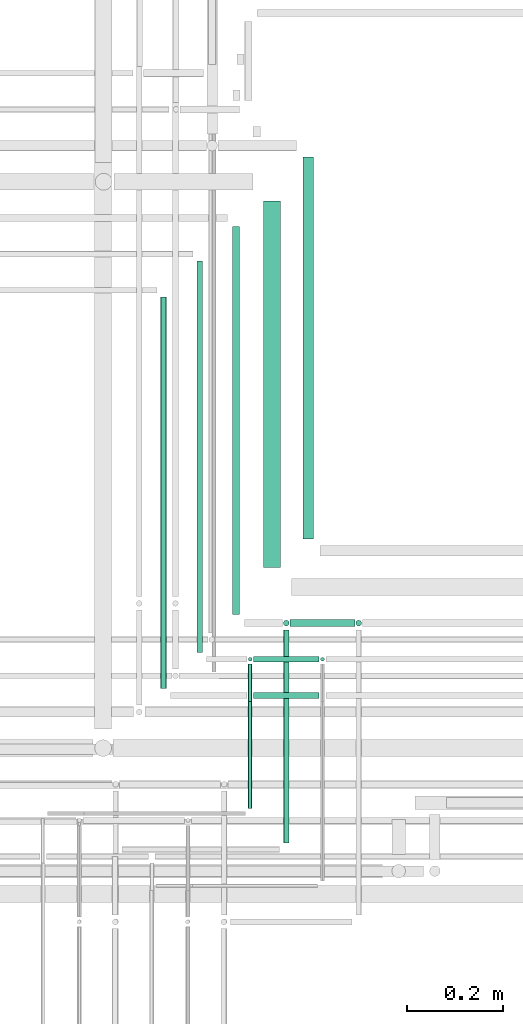
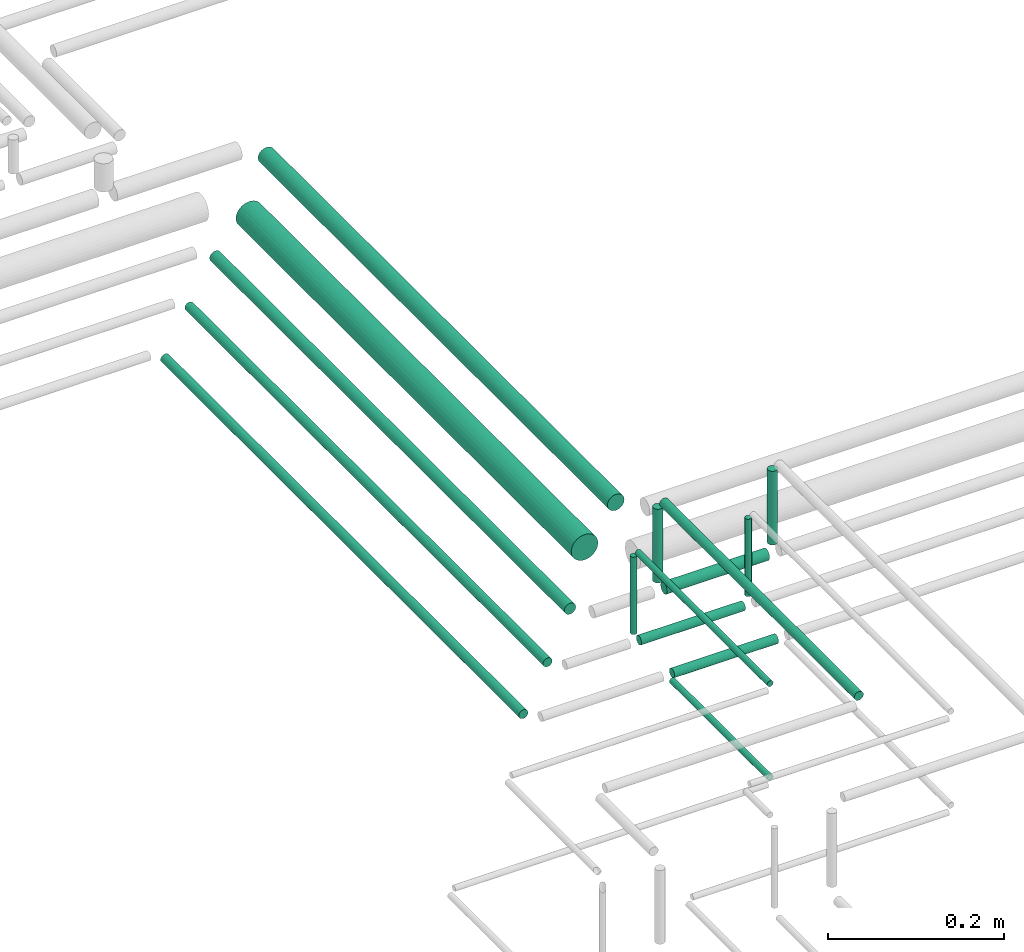
# One storey, part 220 of 331: 15 flow segments.
"""IFC2X3 building model written with IfcOpenShell, lengths in millimetres."""

from ifc_helpers import new_model, entity, si_unit, converted_unit, derived_unit, direction, frame, frame_2d, origin, origin_2d_with_axis, place, context, subcontext, project, spatial, circle, extrude, type_object, element, save


model = new_model("IFC2X3")

# Units and contexts
model_context = context("Model", 3, precision=0.01, world=origin(), true_north=direction((6.12303176911189e-17, 1.0)))
body_context = subcontext(model_context, "Body", "Model", "MODEL_VIEW")
ifc_project = project(units=[si_unit("LENGTHUNIT", "METRE", prefix="MILLI"), si_unit("AREAUNIT", "SQUARE_METRE"), si_unit("VOLUMEUNIT", "CUBIC_METRE"), converted_unit("PLANEANGLEUNIT", "DEGREE", entity("IfcRatioMeasure", 0.0174532925199433), si_unit("PLANEANGLEUNIT", "RADIAN"), dimensions=[0, 0, 0, 0, 0, 0, 0]), si_unit("MASSUNIT", "GRAM", prefix="KILO"), derived_unit("MASSDENSITYUNIT", [(si_unit("MASSUNIT", "GRAM", prefix="KILO"), 1), (si_unit("LENGTHUNIT", "METRE"), -3)]), derived_unit("MOMENTOFINERTIAUNIT", [(si_unit("LENGTHUNIT", "METRE"), 4)]), si_unit("TIMEUNIT", "SECOND"), si_unit("FREQUENCYUNIT", "HERTZ"), si_unit("THERMODYNAMICTEMPERATUREUNIT", "DEGREE_CELSIUS"), derived_unit("THERMALTRANSMITTANCEUNIT", [(si_unit("MASSUNIT", "GRAM", prefix="KILO"), 1), (si_unit("THERMODYNAMICTEMPERATUREUNIT", "KELVIN"), -1), (si_unit("TIMEUNIT", "SECOND"), -3)]), derived_unit("VOLUMETRICFLOWRATEUNIT", [(si_unit("LENGTHUNIT", "METRE"), 3), (si_unit("TIMEUNIT", "SECOND"), -1)]), derived_unit("MASSFLOWRATEUNIT", [(si_unit("MASSUNIT", "GRAM", prefix="KILO"), 1), (si_unit("TIMEUNIT", "SECOND"), -1)]), derived_unit("ROTATIONALFREQUENCYUNIT", [(si_unit("TIMEUNIT", "SECOND"), -1)]), si_unit("ELECTRICCURRENTUNIT", "AMPERE"), si_unit("ELECTRICVOLTAGEUNIT", "VOLT"), si_unit("POWERUNIT", "WATT"), si_unit("FORCEUNIT", "NEWTON", prefix="KILO"), si_unit("ILLUMINANCEUNIT", "LUX"), si_unit("LUMINOUSFLUXUNIT", "LUMEN"), si_unit("LUMINOUSINTENSITYUNIT", "CANDELA"), derived_unit("USERDEFINED", [(si_unit("MASSUNIT", "GRAM", prefix="KILO"), -1), (si_unit("LENGTHUNIT", "METRE"), -2), (si_unit("TIMEUNIT", "SECOND"), 3), (si_unit("LUMINOUSFLUXUNIT", "LUMEN"), 1)]), derived_unit("LINEARVELOCITYUNIT", [(si_unit("LENGTHUNIT", "METRE"), 1), (si_unit("TIMEUNIT", "SECOND"), -1)]), si_unit("PRESSUREUNIT", "PASCAL"), derived_unit("USERDEFINED", [(si_unit("LENGTHUNIT", "METRE"), -2), (si_unit("MASSUNIT", "GRAM", prefix="KILO"), 1), (si_unit("TIMEUNIT", "SECOND"), -2)]), derived_unit("LINEARFORCEUNIT", [(si_unit("MASSUNIT", "GRAM", prefix="KILO"), 1), (si_unit("LENGTHUNIT", "METRE"), 1), (si_unit("TIMEUNIT", "SECOND"), -2), (si_unit("LENGTHUNIT", "METRE"), -1)]), derived_unit("PLANARFORCEUNIT", [(si_unit("MASSUNIT", "GRAM", prefix="KILO"), 1), (si_unit("LENGTHUNIT", "METRE"), 1), (si_unit("TIMEUNIT", "SECOND"), -2), (si_unit("LENGTHUNIT", "METRE"), -2)])], contexts=[model_context])

# Site, building, storey
site_placement = place(None, frame((0.0, -0.00077364408347762, 0.0)))
site = spatial("IfcSite", under=ifc_project, at=site_placement, CompositionType="ELEMENT")
building_placement = place(site_placement, origin())
building = spatial("IfcBuilding", under=site, at=building_placement, CompositionType="ELEMENT")
storey_placement = place(building_placement, origin())
storey = spatial("IfcBuildingStorey", under=building, at=storey_placement, CompositionType="ELEMENT", Elevation=0.0)

# Flow segments
pipe_segment_type = type_object("IfcPipeSegmentType", PredefinedType="NOTDEFINED")
flow_segment_1_placement = place(building_placement, frame((62112.9290801959, 8573.81073448242, 18442.4047277641)))
element("IfcFlowSegment", 1, at=flow_segment_1_placement, inside=storey, type_object=pipe_segment_type, context=body_context, shape_type="SweptSolid", body=[
    extrude(circle(Radius=6.0, at=frame_2d((0.0, -2.16573425859679e-12), x_axis=(1.0, 0.0))), frame((7.59527223591454, 0.0, 7.59527223591454), z_axis=(0.0, 1.0, 0.0), x_axis=(1.0, 0.0, 0.0)), (0.0, 0.0, 1.0), 812.189265517507),
])
flow_segment_2_placement = place(building_placement, frame((62187.9290801959, 8648.81073448242, 18442.4047277641)))
element("IfcFlowSegment", 2, at=flow_segment_2_placement, inside=storey, type_object=pipe_segment_type, context=body_context, shape_type="SweptSolid", body=[
    extrude(circle(Radius=6.0, at=frame_2d((0.0, 2.16573425859679e-12), x_axis=(1.0, 0.0))), frame((7.59527223591454, 0.0, 7.59527223591887), z_axis=(0.0, 1.0, 0.0), x_axis=(1.0, 0.0, 0.0)), (0.0, 0.0, 1.0), 812.189265517507),
])
flow_segment_3_placement = place(building_placement, frame((62261.4290801959, 8727.81073448242, 18440.9047277641)))
element("IfcFlowSegment", 3, at=flow_segment_3_placement, inside=storey, type_object=pipe_segment_type, context=body_context, shape_type="SweptSolid", body=[
    extrude(circle(Radius=7.5, at=origin_2d_with_axis()), frame((9.09527223591419, 0.0, 9.09527223591636), z_axis=(0.0, 1.0, 0.0), x_axis=(1.0, 0.0, 0.0)), (0.0, 0.0, 1.0), 804.189265517482),
])
flow_segment_4_placement = place(building_placement, frame((62326.4290801959, 8824.81073448212, 18430.9047277641)))
element("IfcFlowSegment", 4, at=flow_segment_4_placement, inside=storey, type_object=pipe_segment_type, context=body_context, shape_type="SweptSolid", body=[
    extrude(circle(Radius=17.5, at=origin_2d_with_axis()), frame((19.0952722359119, 0.0, 19.0952722359163), z_axis=(0.0, 1.0, 0.0), x_axis=(1.0, 0.0, 0.0)), (0.0, 0.0, 1.0), 760.189265517799),
])
flow_segment_5_placement = place(building_placement, frame((62407.9290801959, 8883.81073448209, 18437.4047277641)))
element("IfcFlowSegment", 5, at=flow_segment_5_placement, inside=storey, type_object=pipe_segment_type, context=body_context, shape_type="SweptSolid", body=[
    extrude(circle(Radius=11.0, at=origin_2d_with_axis()), frame((12.5952722359134, 0.0, 12.5952722359156), z_axis=(0.0, 1.0, 0.0), x_axis=(1.0, 0.0, 0.0)), (0.0, 0.0, 1.0), 792.189265517839),
])
flow_segment_6_placement = place(building_placement, frame((62517.4135312672, 8702.21546224652, 18464.0)))
element("IfcFlowSegment", 6, at=flow_segment_6_placement, inside=storey, type_object=pipe_segment_type, context=body_context, shape_type="SweptSolid", body=[
    extrude(circle(Radius=6.0, at=origin_2d_with_axis()), frame((7.59527223591454, 7.59527223591562, 0.0), z_axis=(0.0, 0.0, 1.0), x_axis=(-1.0, 0.0, 0.0)), (0.0, 0.0, 1.0), 101.99999999923),
])
flow_segment_7_placement = place(building_placement, frame((62444.4135312672, 8629.21546224653, 18463.0)))
element("IfcFlowSegment", 7, at=flow_segment_7_placement, inside=storey, type_object=pipe_segment_type, context=body_context, shape_type="SweptSolid", body=[
    extrude(circle(Radius=4.0, at=origin_2d_with_axis()), frame((5.59527223591499, 5.59527223591607, 0.0), z_axis=(0.0, 0.0, 1.0), x_axis=(-1.0, 0.0, 0.0)), (0.0, 0.0, 1.0), 106.999999999168),
])
flow_segment_8_placement = place(building_placement, frame((62367.4135312672, 8254.14880665487, 18572.4047277633)))
element("IfcFlowSegment", 8, at=flow_segment_8_placement, inside=storey, type_object=pipe_segment_type, context=body_context, shape_type="SweptSolid", body=[
    extrude(circle(Radius=6.0, at=frame_2d((0.0, 2.16573425859679e-12), x_axis=(1.0, 0.0))), frame((7.59527223591454, 0.0, 7.59527223591454), z_axis=(0.0, 1.0, 0.0), x_axis=(-1.0, 0.0, 0.0)), (0.0, 0.0, 1.0), 441.661927827564),
])
flow_segment_9_placement = place(building_placement, frame((62367.4135312672, 8702.21546224652, 18464.0)))
element("IfcFlowSegment", 9, at=flow_segment_9_placement, inside=storey, type_object=pipe_segment_type, context=body_context, shape_type="SweptSolid", body=[
    extrude(circle(Radius=6.0, at=frame_2d((0.0, -1.08286712929839e-12), x_axis=(1.0, 0.0))), frame((7.59527223591454, 7.59527223591454, 0.0), z_axis=(0.0, 0.0, 1.0), x_axis=(-1.0, 0.0, 0.0)), (0.0, 0.0, 1.0), 101.999999999219),
])
flow_segment_10_placement = place(storey_placement, frame((62383.0088035031, 8700.71546224652, 18440.9047277641)))
element("IfcFlowSegment", 10, at=flow_segment_10_placement, inside=storey, type_object=pipe_segment_type, context=body_context, shape_type="SweptSolid", body=[
    extrude(circle(Radius=7.5, at=frame_2d((1.08286712929839e-12, -2.16573425859679e-12), x_axis=(1.0, 0.0))), frame((0.0, 9.09527223591528, 9.09527223591853), z_axis=(1.0, 0.0, 0.0), x_axis=(0.0, 1.0, 0.0)), (0.0, 0.0, 1.0), 134.000000000004),
])
flow_segment_11_placement = place(building_placement, frame((62294.4135312672, 8325.14880665487, 18574.4047277633)))
element("IfcFlowSegment", 11, at=flow_segment_11_placement, inside=storey, type_object=pipe_segment_type, context=body_context, shape_type="SweptSolid", body=[
    extrude(circle(Radius=4.0, at=origin_2d_with_axis()), frame((5.59527223591499, 0.0, 5.59527223591499), z_axis=(0.0, 1.0, 0.0), x_axis=(-1.0, 0.0, 0.0)), (0.0, 0.0, 1.0), 299.661927827579),
])
flow_segment_12_placement = place(building_placement, frame((62294.4135312672, 8629.21546224653, 18463.0)))
element("IfcFlowSegment", 12, at=flow_segment_12_placement, inside=storey, type_object=pipe_segment_type, context=body_context, shape_type="SweptSolid", body=[
    extrude(circle(Radius=4.0, at=frame_2d((0.0, 1.08286712929839e-12), x_axis=(1.0, 0.0))), frame((5.59527223591499, 5.59527223591716, 0.0), z_axis=(0.0, 0.0, 1.0), x_axis=(-1.0, 0.0, 0.0)), (0.0, 0.0, 1.0), 106.999999999159),
])
flow_segment_13_placement = place(storey_placement, frame((62307.0088035031, 8627.21546224653, 18442.4047277641)))
element("IfcFlowSegment", 13, at=flow_segment_13_placement, inside=storey, type_object=pipe_segment_type, context=body_context, shape_type="SweptSolid", body=[
    extrude(circle(Radius=6.0, at=frame_2d((-2.16573425859679e-12, -2.16573425859679e-12), x_axis=(1.0, 0.0))), frame((0.0, 7.59527223591778, 7.59527223591887), z_axis=(1.0, 0.0, 0.0), x_axis=(0.0, 1.0, 0.0)), (0.0, 0.0, 1.0), 136.000000000004),
])
flow_segment_14_placement = place(building_placement, frame((62294.4135312672, 8325.14880665488, 18444.4047277641)))
element("IfcFlowSegment", 14, at=flow_segment_14_placement, inside=storey, type_object=pipe_segment_type, context=body_context, shape_type="SweptSolid", body=[
    extrude(circle(Radius=4.0, at=origin_2d_with_axis()), frame((5.59527223591499, 0.0, 5.59527223591499), z_axis=(0.0, 1.0, 0.0), x_axis=(-1.0, 0.0, 0.0)), (0.0, 0.0, 1.0), 221.661927827553),
])
flow_segment_15_placement = place(storey_placement, frame((62307.0088035031, 8552.21546224651, 18442.4047277641)))
element("IfcFlowSegment", 15, at=flow_segment_15_placement, inside=storey, type_object=pipe_segment_type, context=body_context, shape_type="SweptSolid", body=[
    extrude(circle(Radius=6.0, at=frame_2d((2.16573425859679e-12, 0.0), x_axis=(1.0, 0.0))), frame((0.0, 7.59527223591887, 7.5952722359167), z_axis=(1.0, 0.0, 0.0), x_axis=(0.0, 1.0, 0.0)), (0.0, 0.0, 1.0), 136.000000000004),
])

save(model, "model.ifc")
